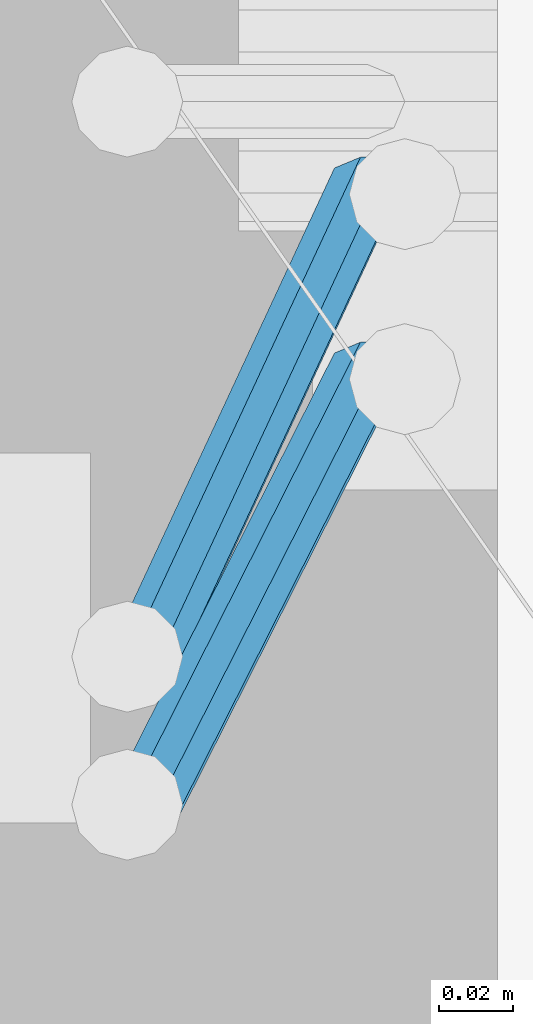
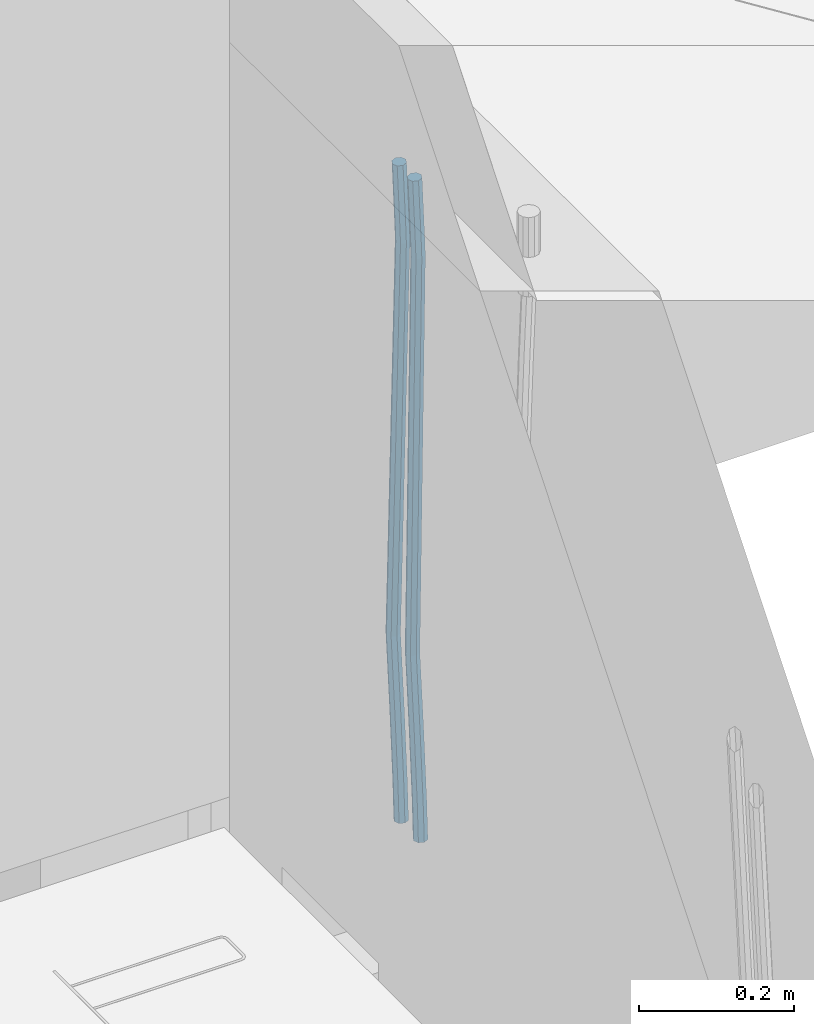
# One storey, part 124 of 350: 2 beams, 1 element without a shape of its own.
"""IFC2X3 building model written with IfcOpenShell, lengths in millimetres."""

from ifc_helpers import new_model, si_unit, frame, origin_with_axes, place, context, subcontext, project, spatial, faceted_brep, material, type_object, element, aggregate, save


model = new_model("IFC2X3")

# Units and contexts
model_context = context("Model", 3, precision=1e-05, world=origin_with_axes())
body_context = subcontext(model_context, "Body", "Model", "MODEL_VIEW")
ifc_project = project(units=[si_unit("LENGTHUNIT", "METRE", prefix="MILLI"), si_unit("AREAUNIT", "SQUARE_METRE"), si_unit("VOLUMEUNIT", "CUBIC_METRE"), si_unit("MASSUNIT", "GRAM", prefix="KILO"), si_unit("TIMEUNIT", "SECOND"), si_unit("PLANEANGLEUNIT", "RADIAN"), si_unit("SOLIDANGLEUNIT", "STERADIAN"), si_unit("THERMODYNAMICTEMPERATUREUNIT", "DEGREE_CELSIUS"), si_unit("LUMINOUSINTENSITYUNIT", "LUMEN")], contexts=[model_context])

# Site, building, storey
site_placement = place(None, origin_with_axes())
site = spatial("IfcSite", under=ifc_project, at=site_placement, CompositionType="ELEMENT")
building_placement = place(site_placement, origin_with_axes())
building = spatial("IfcBuilding", under=site, at=building_placement, CompositionType="ELEMENT")
storey_placement = place(building_placement, origin_with_axes())
storey = spatial("IfcBuildingStorey", under=building, at=storey_placement, Name="2", CompositionType="ELEMENT", Elevation=0.0)

# Assembly, beams
assembly_placement = place(storey_placement, origin_with_axes())
assembly = element("IfcElementAssembly", 1, at=assembly_placement, inside=storey, AssemblyPlace="NOTDEFINED", PredefinedType="REINFORCEMENT_UNIT")
ifc_material = material()
beam_type = type_object("IfcBeamType", Name="D20", PredefinedType="NOTDEFINED")
beam_1_placement = place(assembly_placement, frame((22385.0000022791, 20210.0000000039, 86267.5), z_axis=(-0.999642804636942, -0.000205726999925762, -0.0267249099902983), x_axis=(-0.0267249099948371, 4.30000201934385e-08, 0.999642825806181)))
beam_1 = element("IfcBeam", 2, at=beam_1_placement, type_object=beam_type, material=ifc_material, Name="JM20", ObjectType="D20", context=body_context, shape_type="Brep", body=[
    faceted_brep([(0.0, -10.0, 0.0), (-4.19531716033816e-08, -7.07106781186667, -7.07106781187031), (60.4266690400545, -7.0710677960451, -7.07106780570757), (60.4266690441291, -9.99999998418934, 6.15546014159918e-09), (0.0, 0.0, -10.0), (60.426669036824, 1.58106558956206e-08, -9.99999999384454), (4.196772351861e-08, 7.07106781186303, -7.07106781186667), (60.4266690363438, 7.07106782768096, -7.07106780570757), (0.0, 10.0, 0.0), (60.4266690388904, 10.0000000158179, 6.15182216279209e-09), (4.196772351861e-08, 7.07106781185939, 7.07106781185939), (60.4266690429649, 7.07106782768096, 7.07106781802577), (0.0, 0.0, 10.0), (60.4266690461809, 1.58179318532348e-08, 10.0000000061555), (-4.19531716033816e-08, -7.07106781187031, 7.07106781185939), (60.4266690466611, -7.07106779605238, 7.07106781802213), (61.0378400410118, -7.07106779588503, -7.07106780564936), (60.991799419251, -9.99999998403655, 6.21366780251265e-09), (61.0569027789461, 1.5985278878361e-08, -9.99999999378269), (61.0378209396877, 7.07106782784831, -7.07106780564936), (60.9917724058905, 10.0000000159635, 6.21366780251265e-09), (60.9457317841297, 7.07106782781193, 7.0710678180767), (60.9266690461809, 1.59488990902901e-08, 10.0000000062028), (60.9457508854539, -7.07106779591413, 7.0710678180767), (61.6489592143771, -7.07106614513759, -7.06310863441468), (61.5568818710308, -9.9999984576425, 0.00735959856683621), (61.6870830769039, 1.71821739058942e-06, -9.99179257185824), (61.6489210170112, 7.07106947854481, -7.06310888312146), (61.556827851804, 10.0000015422847, 0.00735924683976918), (61.4647505084577, 7.07106922979438, 7.07782747982128), (61.4266266459163, 1.36643211590126e-06, 10.0065114172685), (61.464788705809, -7.07106639389531, 7.07782772852806), (176.543135720174, -7.07075579406956, -5.56673531796696), (176.451058376813, -9.99968810657447, 1.50373291501455), (176.581259582701, 0.000312069292704109, -8.49541925541052), (176.543097522794, 7.07137982961285, -5.56673556667374), (176.451004357587, 10.00031189336, 1.50373256329476), (176.35892701424, 7.07137958085514, 8.57420079627263), (176.320803151699, 0.000311717507429421, 11.5028847337162), (176.358965211621, -7.07075604281999, 8.57420104497578), (177.098753836006, -7.07075429323595, -5.55949898843028), (176.98362511232, -9.99968666800123, 1.510669025065), (177.146421932586, 0.000313595905026887, -8.48805862247536), (177.098706077581, 7.07138133041735, -5.55949936166144), (176.983557571715, 10.0003133318824, 1.51066849724157), (176.868428848029, 7.07138095712435, 8.58083651073321), (176.820760751449, 0.000313067976094317, 11.5093961447819), (176.868476606425, -7.07075466652896, 8.58083688396073), (177.654312950661, -7.07075204110879, -5.54863964998367), (177.516135294456, -9.99968450931192, 1.52107783331303), (177.711524267797, 0.000315886711177882, -8.47701274570863), (177.654255632195, 7.07138358250813, -5.54864021007961), (177.516054233929, 10.0003154905207, 1.5210770412159), (177.377876577739, 7.0713830223176, 8.59079452451624), (177.320665260588, 0.000315094497636892, 11.5191676202448), (177.377933896176, -7.07075260129932, 8.59079508461218), (298.815467493725, -7.07026087564373, -3.18034085036197), (298.677289837564, -9.99919334385049, 3.88937663293109), (298.872678810818, 0.000807052179879975, -6.10871394609057), (298.815410175172, 7.07187474796592, -3.18034141045791), (298.677208776877, 10.0008066559858, 3.8893758408376), (298.539031120687, 7.07187418777903, 10.9590933241343), (298.481819803608, 0.000806259959063027, 13.8874664198629), (298.539088439255, -7.07026143583425, 10.9590938842302), (299.67009200262, -7.07025741116013, -3.16363577515585), (299.177194346703, -9.99919131733259, 3.89914810839764), (300.339709364547, 0.00081299923840561, -6.08003836345233), (300.79379366347, 7.07188276795205, -3.141670573601), (300.766348475532, 10.0008151249531, 3.9302115943392), (300.273450819615, 7.07188121878789, 10.9929954778927), (299.603833457673, 0.000810808385722339, 13.9093980661892), (299.14974915878, -7.07025896033156, 10.9710302763342), (300.512913202241, -7.2052330304432, -3.11785238911762), (299.67019462194, -10.0781440269784, 3.92592866628183), (301.78647860451, -0.230883325217292, -6.00144756073496), (302.74485348865, 6.7594256201337, -3.03568590543364), (302.826634845376, 9.67086563057819, 4.04212962187376), (301.983916265046, 6.79795463404662, 11.0859106772696), (300.710350862806, -0.1763950711902, 13.9695058488869), (299.751975978652, -7.16670401652664, 11.0037441935892), (1016.06255465306, -121.798643856979, 35.7519404949198), (1015.21983607276, -124.67155485351, 42.7957215503156), (1017.33612005532, -114.824294151749, 32.8683453233025), (1018.29449493947, -107.833985206405, 35.8341069786038), (1018.3762762962, -104.922545195961, 42.9119225059112), (1017.5335577159, -107.795456192489, 49.955703561307), (1016.25999231363, -114.769805897726, 52.8392987329207), (1015.30161742949, -121.760114843066, 49.873537077623), (1017.64070561952, -122.051380622637, 35.8376681616683), (1017.15071056716, -124.980779373207, 42.9006097192614), (1018.3470245444, -114.986187871924, 32.9232592605622), (1018.85591529503, -107.923895213658, 35.8646042239052), (1018.86927657142, -105.001497905603, 42.9387030637918), (1018.37928151908, -107.930896656177, 50.0016446213813), (1017.67296259418, -114.996089406886, 52.9160535224946), (1017.16407184357, -122.058382065152, 49.974708559148), (1019.2409857497, -122.072248321667, 35.8589665747968), (1019.10866018859, -125.006311092715, 42.9266684193208), (1019.37210414821, -114.99955493951, 32.9369022274914), (1019.42520800454, -107.931318807005, 35.8721810419192), (1019.36918979988, -105.008016788513, 42.9453564979449), (1019.23686423877, -107.942079559562, 50.0130583424689), (1019.10574584025, -115.014772941722, 52.9351226897743), (1019.05264198393, -122.083009074224, 49.9998438753428), (1040.41841028637, -122.348402548138, 36.140820687895), (1040.28608472526, -125.282465319182, 43.2085225324154), (1040.54952868487, -115.275709165981, 33.2187563405823), (1040.60263254121, -108.207473033472, 36.1540351550175), (1040.54661433655, -105.284171014984, 43.2272106110395), (1040.41428877544, -108.218233786029, 50.2949124555635), (1040.28317037692, -115.290927168189, 53.2169768028689), (1040.2300665206, -122.359163300694, 50.281697988441), (1041.05380050941, -122.356688054962, 36.1492772094862), (1040.9461697993, -125.291072847573, 43.2173077221705), (1041.12777671829, -115.283249537002, 33.2264523466038), (1041.12476416609, -108.214281644912, 36.1609842977596), (1041.04652756499, -105.290689897894, 43.233864045189), (1040.93889685487, -108.225074690508, 50.3018945578842), (1040.864920646, -115.298513208465, 53.224719420763), (1040.86793319821, -122.367481100559, 50.2901874695999), (1041.68924454234, -122.354813008245, 36.1575394084866), (1041.60631061636, -125.289104322157, 43.2258984974833), (1041.7060739864, -115.281553105524, 33.2339534458297), (1041.64694048846, -108.212744334829, 36.1677376156767), (1041.54648364961, -105.289199004201, 43.2403209404038), (1041.4635497236, -108.22349031812, 50.3086800294004), (1041.44672027956, -115.296750220841, 53.2322659920574), (1041.50585377749, -122.365558991532, 50.2984818222067), (1141.71003235725, -122.056550144174, 37.4549136692622), (1141.62709843126, -124.990841458086, 44.5232727582552), (1141.72686180132, -114.983290241453, 34.5313277066016), (1141.66772830336, -107.914481470762, 37.4651118764486), (1141.56727146452, -104.99093614013, 44.5376952011684), (1141.48433753852, -107.925227454049, 51.6060542901723), (1141.46750809446, -114.99848735677, 54.5296402528293), (1141.52664159241, -122.067296127461, 51.5958560829858)], [[[0, 1, 2, 3]], [[1, 4, 5, 2]], [[4, 6, 7, 5]], [[6, 8, 9, 7]], [[8, 10, 11, 9]], [[10, 12, 13, 11]], [[12, 14, 15, 13]], [[14, 0, 3, 15]], [[14, 12, 10, 8, 6, 4, 1, 0]], [[3, 2, 16, 17]], [[2, 5, 18, 16]], [[5, 7, 19, 18]], [[7, 9, 20, 19]], [[9, 11, 21, 20]], [[11, 13, 22, 21]], [[13, 15, 23, 22]], [[15, 3, 17, 23]], [[17, 16, 24, 25]], [[16, 18, 26, 24]], [[18, 19, 27, 26]], [[19, 20, 28, 27]], [[20, 21, 29, 28]], [[21, 22, 30, 29]], [[22, 23, 31, 30]], [[23, 17, 25, 31]], [[25, 24, 32, 33]], [[24, 26, 34, 32]], [[26, 27, 35, 34]], [[27, 28, 36, 35]], [[28, 29, 37, 36]], [[29, 30, 38, 37]], [[30, 31, 39, 38]], [[31, 25, 33, 39]], [[33, 32, 40, 41]], [[32, 34, 42, 40]], [[34, 35, 43, 42]], [[35, 36, 44, 43]], [[36, 37, 45, 44]], [[37, 38, 46, 45]], [[38, 39, 47, 46]], [[39, 33, 41, 47]], [[41, 40, 48, 49]], [[40, 42, 50, 48]], [[42, 43, 51, 50]], [[43, 44, 52, 51]], [[44, 45, 53, 52]], [[45, 46, 54, 53]], [[46, 47, 55, 54]], [[47, 41, 49, 55]], [[49, 48, 56, 57]], [[48, 50, 58, 56]], [[50, 51, 59, 58]], [[51, 52, 60, 59]], [[52, 53, 61, 60]], [[53, 54, 62, 61]], [[54, 55, 63, 62]], [[55, 49, 57, 63]], [[57, 56, 64, 65]], [[56, 58, 66, 64]], [[58, 59, 67, 66]], [[59, 60, 68, 67]], [[60, 61, 69, 68]], [[61, 62, 70, 69]], [[62, 63, 71, 70]], [[63, 57, 65, 71]], [[65, 64, 72, 73]], [[64, 66, 74, 72]], [[66, 67, 75, 74]], [[67, 68, 76, 75]], [[68, 69, 77, 76]], [[69, 70, 78, 77]], [[70, 71, 79, 78]], [[71, 65, 73, 79]], [[73, 72, 80, 81]], [[72, 74, 82, 80]], [[74, 75, 83, 82]], [[75, 76, 84, 83]], [[76, 77, 85, 84]], [[77, 78, 86, 85]], [[78, 79, 87, 86]], [[79, 73, 81, 87]], [[81, 80, 88, 89]], [[80, 82, 90, 88]], [[82, 83, 91, 90]], [[83, 84, 92, 91]], [[84, 85, 93, 92]], [[85, 86, 94, 93]], [[86, 87, 95, 94]], [[87, 81, 89, 95]], [[89, 88, 96, 97]], [[88, 90, 98, 96]], [[90, 91, 99, 98]], [[91, 92, 100, 99]], [[92, 93, 101, 100]], [[93, 94, 102, 101]], [[94, 95, 103, 102]], [[95, 89, 97, 103]], [[97, 96, 104, 105]], [[96, 98, 106, 104]], [[98, 99, 107, 106]], [[99, 100, 108, 107]], [[100, 101, 109, 108]], [[101, 102, 110, 109]], [[102, 103, 111, 110]], [[103, 97, 105, 111]], [[105, 104, 112, 113]], [[104, 106, 114, 112]], [[106, 107, 115, 114]], [[107, 108, 116, 115]], [[108, 109, 117, 116]], [[109, 110, 118, 117]], [[110, 111, 119, 118]], [[111, 105, 113, 119]], [[113, 112, 120, 121]], [[112, 114, 122, 120]], [[114, 115, 123, 122]], [[115, 116, 124, 123]], [[116, 117, 125, 124]], [[117, 118, 126, 125]], [[118, 119, 127, 126]], [[119, 113, 121, 127]], [[121, 120, 128, 129]], [[120, 122, 130, 128]], [[122, 123, 131, 130]], [[123, 124, 132, 131]], [[124, 125, 133, 132]], [[125, 126, 134, 133]], [[126, 127, 135, 134]], [[127, 121, 129, 135]], [[130, 131, 132, 133, 134, 135, 129, 128]]]),
])
beam_2_placement = place(assembly_placement, frame((22385.0000022791, 20260.0000000039, 86267.5), z_axis=(-0.999642804636942, -0.000205726999925762, -0.0267249099902983), x_axis=(-0.0267249099948371, 4.30000201934385e-08, 0.999642825806181)))
beam_2 = element("IfcBeam", 3, at=beam_2_placement, type_object=beam_type, material=ifc_material, Name="JM20", ObjectType="D20", context=body_context, shape_type="Brep", body=[
    faceted_brep([(0.0, -10.0, 0.0), (-4.19531716033816e-08, -7.07106781186667, -7.07106781187031), (60.4266690400545, -7.0710677960451, -7.07106780570757), (60.4266690441291, -9.99999998418934, 6.15546014159918e-09), (0.0, 0.0, -10.0), (60.426669036824, 1.58106558956206e-08, -9.99999999384454), (4.196772351861e-08, 7.07106781186303, -7.07106781186667), (60.4266690363438, 7.07106782768096, -7.07106780570757), (0.0, 10.0, 0.0), (60.4266690388904, 10.0000000158179, 6.15182216279209e-09), (4.196772351861e-08, 7.07106781185939, 7.07106781185939), (60.4266690429649, 7.07106782768096, 7.07106781802577), (0.0, 0.0, 10.0), (60.4266690461809, 1.58179318532348e-08, 10.0000000061555), (-4.19531716033816e-08, -7.07106781187031, 7.07106781185939), (60.4266690466611, -7.07106779605238, 7.07106781802213), (61.0378400410118, -7.07106779588503, -7.07106780564936), (60.991799419251, -9.99999998403655, 6.21366780251265e-09), (61.0569027789461, 1.5985278878361e-08, -9.99999999378269), (61.0378209396877, 7.07106782784831, -7.07106780564936), (60.9917724058905, 10.0000000159635, 6.21366780251265e-09), (60.9457317841297, 7.07106782781193, 7.0710678180767), (60.9266690461809, 1.59488990902901e-08, 10.0000000062028), (60.9457508854539, -7.07106779591413, 7.0710678180767), (61.6489592143771, -7.07106614513759, -7.06310863441468), (61.5568818710308, -9.9999984576425, 0.00735959856683621), (61.6870830769039, 1.71821739058942e-06, -9.99179257185824), (61.6489210170112, 7.07106947854481, -7.06310888312146), (61.556827851804, 10.0000015422847, 0.00735924683976918), (61.4647505084577, 7.07106922979438, 7.07782747982128), (61.4266266459163, 1.36643211590126e-06, 10.0065114172685), (61.464788705809, -7.07106639389531, 7.07782772852806), (176.543135720174, -7.07075579406956, -5.56673531796696), (176.451058376813, -9.99968810657447, 1.50373291501455), (176.581259582701, 0.000312069292704109, -8.49541925541052), (176.543097522794, 7.07137982961285, -5.56673556667374), (176.451004357587, 10.00031189336, 1.50373256329476), (176.35892701424, 7.07137958085514, 8.57420079627263), (176.320803151699, 0.000311717507429421, 11.5028847337162), (176.358965211621, -7.07075604281999, 8.57420104497578), (177.098753836006, -7.07075429323595, -5.55949898843028), (176.98362511232, -9.99968666800123, 1.510669025065), (177.146421932586, 0.000313595905026887, -8.48805862247536), (177.098706077581, 7.07138133041735, -5.55949936166144), (176.983557571715, 10.0003133318824, 1.51066849724157), (176.868428848029, 7.07138095712435, 8.58083651073321), (176.820760751449, 0.000313067976094317, 11.5093961447819), (176.868476606425, -7.07075466652896, 8.58083688396073), (177.654312950661, -7.07075204110879, -5.54863964998367), (177.516135294456, -9.99968450931192, 1.52107783331303), (177.711524267797, 0.000315886711177882, -8.47701274570863), (177.654255632195, 7.07138358250813, -5.54864021007961), (177.516054233929, 10.0003154905207, 1.5210770412159), (177.377876577739, 7.0713830223176, 8.59079452451624), (177.320665260588, 0.000315094497636892, 11.5191676202448), (177.377933896176, -7.07075260129932, 8.59079508461218), (298.747348659163, -7.07026115178815, -3.18167234769862), (298.609171002972, -9.99919361999127, 3.88804513559444), (298.804559976241, 0.000806776042736601, -6.11004544342359), (298.747291340609, 7.07187447182878, -3.18167290779093), (298.6090899423, 10.0008063798487, 3.88804434350459), (298.470912286124, 7.07187391164553, 10.9577618268013), (298.413700969017, 0.000805983818281675, 13.8861349225299), (298.470969604663, -7.07026171197504, 10.9577623868936), (299.621796148553, -7.07025760694523, -3.16457979895495), (299.109075512111, -9.99919159347337, 3.89781661105735), (300.339527547287, 0.000812998507171869, -6.08004191737928), (300.841832389109, 7.07188296269669, -3.14073157581515), (300.834467310124, 10.0008154011011, 3.93154309166857), (300.321746673711, 7.071881414573, 10.9939395016918), (299.604015274963, 0.000810809124232037, 13.9094016201125), (299.10171043314, -7.07025915506892, 10.9700912785447), (300.482221804094, -7.22003554013645, -3.11783764522261), (299.6009640134, -10.0848167054246, 3.92453818520153), (301.849881793387, -0.262100753436243, -5.99799274798715), (302.902787308223, 6.71312382273391, -3.02877132562207), (303.024160577959, 9.61964623225504, 4.05049698233779), (302.142902787265, 6.75486506696689, 11.0928728127619), (300.775242797987, -0.203069719733321, 13.9730279155228), (299.722337283136, -7.17829429590347, 11.0038064931578), (1015.90349195308, -131.756442041384, 35.7470320599059), (1015.02223416237, -134.621223206676, 42.78940789033), (1017.27115194236, -124.798507254684, 32.8668769571414), (1018.3240574572, -117.823282678513, 35.8360983795064), (1018.44543072693, -114.916760268996, 42.915366687459), (1017.56417293624, -117.781541434284, 49.9577425178868), (1016.19651294696, -124.739476220984, 52.8378976206477), (1015.14360743211, -131.714700797158, 49.8686761982863), (1017.59248966523, -132.050453017066, 35.8387859380055), (1017.08266705039, -134.979891474468, 42.9013397814706), (1018.34688015285, -124.985763814278, 32.9253153045684), (1018.90392679691, -117.924222987145, 35.8675994646364), (1018.93731922821, -115.002385380943, 42.9420882616032), (1018.42749661337, -117.931823838349, 50.0046421050574), (1017.67310612575, -124.996513041137, 52.9181127385018), (1017.11605948168, -132.058053868273, 49.9758285784337), (1019.30904188578, -132.072836907508, 35.8616318370878), (1019.17671408414, -135.007197908155, 42.9292098262158), (1019.44015792056, -125.00002018789, 32.9398659330036), (1019.4932561936, -117.931907859464, 35.8754429544861), (1019.43723245666, -115.008904263857, 42.9487416957491), (1019.30490465506, -117.943265264505, 50.0163196848807), (1019.17378862025, -125.016081984126, 52.9380855889722), (1019.12069034722, -132.084194312552, 50.0025085674824), (1040.41841779022, -132.348103777858, 36.1425802788253), (1040.28608998859, -135.282464778498, 43.2101582679534), (1040.549533825, -125.275287058234, 33.2208143747339), (1040.60263209805, -118.207174729807, 36.15639139622), (1040.54660836112, -115.284171134201, 43.2296901374903), (1040.4142805595, -118.218532134852, 50.2972681266147), (1040.28316452471, -125.291348854476, 53.2190340307025), (1040.23006625166, -132.359461182896, 50.2834570092164), (1041.05380549764, -132.356389251876, 36.1510367669325), (1040.94617491473, -135.291072304968, 43.2189434557404), (1041.1277784054, -125.282827384228, 33.2285103347931), (1041.1247613119, -118.213983309812, 36.1633405068787), (1041.04652158958, -115.290690017111, 43.2363435716397), (1040.93889100666, -118.225373070203, 50.3042502604476), (1040.8649180989, -125.298934937851, 53.226776692587), (1040.86793519241, -132.367779012271, 50.2919465205014), (1041.68924701435, -132.354514251791, 36.1592989706915), (1041.60631558315, -135.289103781222, 43.2275342832399), (1041.70607222033, -125.28113101716, 33.2360113880059), (1041.64693522363, -118.212446044308, 36.1700937543865), (1041.54647767487, -115.289199122199, 43.2428004127432), (1041.46354624369, -118.223788651623, 50.3110357252881), (1041.4467210377, -125.297171886254, 53.2343233079773), (1041.50585803439, -132.365856859102, 50.3002409415931), (1141.71003490323, -132.056251387494, 37.4566732324238), (1141.62710347204, -134.990840916926, 44.5249085449723), (1141.72686010921, -124.982868152867, 34.5333856497382), (1141.66772311251, -117.914183180015, 37.4674680161224), (1141.56726556375, -114.990936257902, 44.5401746744756), (1141.48433413258, -117.92552578733, 51.6084099870168), (1141.46750892658, -124.998909021961, 54.5316975697097), (1141.52664592327, -132.067593994809, 51.5976152033254)], [[[0, 1, 2, 3]], [[1, 4, 5, 2]], [[4, 6, 7, 5]], [[6, 8, 9, 7]], [[8, 10, 11, 9]], [[10, 12, 13, 11]], [[12, 14, 15, 13]], [[14, 0, 3, 15]], [[14, 12, 10, 8, 6, 4, 1, 0]], [[3, 2, 16, 17]], [[2, 5, 18, 16]], [[5, 7, 19, 18]], [[7, 9, 20, 19]], [[9, 11, 21, 20]], [[11, 13, 22, 21]], [[13, 15, 23, 22]], [[15, 3, 17, 23]], [[17, 16, 24, 25]], [[16, 18, 26, 24]], [[18, 19, 27, 26]], [[19, 20, 28, 27]], [[20, 21, 29, 28]], [[21, 22, 30, 29]], [[22, 23, 31, 30]], [[23, 17, 25, 31]], [[25, 24, 32, 33]], [[24, 26, 34, 32]], [[26, 27, 35, 34]], [[27, 28, 36, 35]], [[28, 29, 37, 36]], [[29, 30, 38, 37]], [[30, 31, 39, 38]], [[31, 25, 33, 39]], [[33, 32, 40, 41]], [[32, 34, 42, 40]], [[34, 35, 43, 42]], [[35, 36, 44, 43]], [[36, 37, 45, 44]], [[37, 38, 46, 45]], [[38, 39, 47, 46]], [[39, 33, 41, 47]], [[41, 40, 48, 49]], [[40, 42, 50, 48]], [[42, 43, 51, 50]], [[43, 44, 52, 51]], [[44, 45, 53, 52]], [[45, 46, 54, 53]], [[46, 47, 55, 54]], [[47, 41, 49, 55]], [[49, 48, 56, 57]], [[48, 50, 58, 56]], [[50, 51, 59, 58]], [[51, 52, 60, 59]], [[52, 53, 61, 60]], [[53, 54, 62, 61]], [[54, 55, 63, 62]], [[55, 49, 57, 63]], [[57, 56, 64, 65]], [[56, 58, 66, 64]], [[58, 59, 67, 66]], [[59, 60, 68, 67]], [[60, 61, 69, 68]], [[61, 62, 70, 69]], [[62, 63, 71, 70]], [[63, 57, 65, 71]], [[65, 64, 72, 73]], [[64, 66, 74, 72]], [[66, 67, 75, 74]], [[67, 68, 76, 75]], [[68, 69, 77, 76]], [[69, 70, 78, 77]], [[70, 71, 79, 78]], [[71, 65, 73, 79]], [[73, 72, 80, 81]], [[72, 74, 82, 80]], [[74, 75, 83, 82]], [[75, 76, 84, 83]], [[76, 77, 85, 84]], [[77, 78, 86, 85]], [[78, 79, 87, 86]], [[79, 73, 81, 87]], [[81, 80, 88, 89]], [[80, 82, 90, 88]], [[82, 83, 91, 90]], [[83, 84, 92, 91]], [[84, 85, 93, 92]], [[85, 86, 94, 93]], [[86, 87, 95, 94]], [[87, 81, 89, 95]], [[89, 88, 96, 97]], [[88, 90, 98, 96]], [[90, 91, 99, 98]], [[91, 92, 100, 99]], [[92, 93, 101, 100]], [[93, 94, 102, 101]], [[94, 95, 103, 102]], [[95, 89, 97, 103]], [[97, 96, 104, 105]], [[96, 98, 106, 104]], [[98, 99, 107, 106]], [[99, 100, 108, 107]], [[100, 101, 109, 108]], [[101, 102, 110, 109]], [[102, 103, 111, 110]], [[103, 97, 105, 111]], [[105, 104, 112, 113]], [[104, 106, 114, 112]], [[106, 107, 115, 114]], [[107, 108, 116, 115]], [[108, 109, 117, 116]], [[109, 110, 118, 117]], [[110, 111, 119, 118]], [[111, 105, 113, 119]], [[113, 112, 120, 121]], [[112, 114, 122, 120]], [[114, 115, 123, 122]], [[115, 116, 124, 123]], [[116, 117, 125, 124]], [[117, 118, 126, 125]], [[118, 119, 127, 126]], [[119, 113, 121, 127]], [[121, 120, 128, 129]], [[120, 122, 130, 128]], [[122, 123, 131, 130]], [[123, 124, 132, 131]], [[124, 125, 133, 132]], [[125, 126, 134, 133]], [[126, 127, 135, 134]], [[127, 121, 129, 135]], [[130, 131, 132, 133, 134, 135, 129, 128]]]),
])
aggregate(assembly, [beam_1, beam_2])

save(model, "model.ifc")
